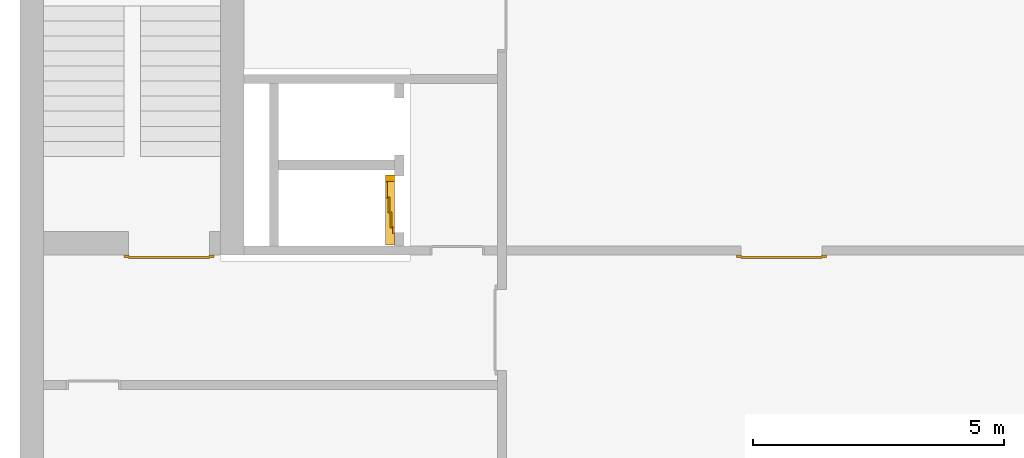
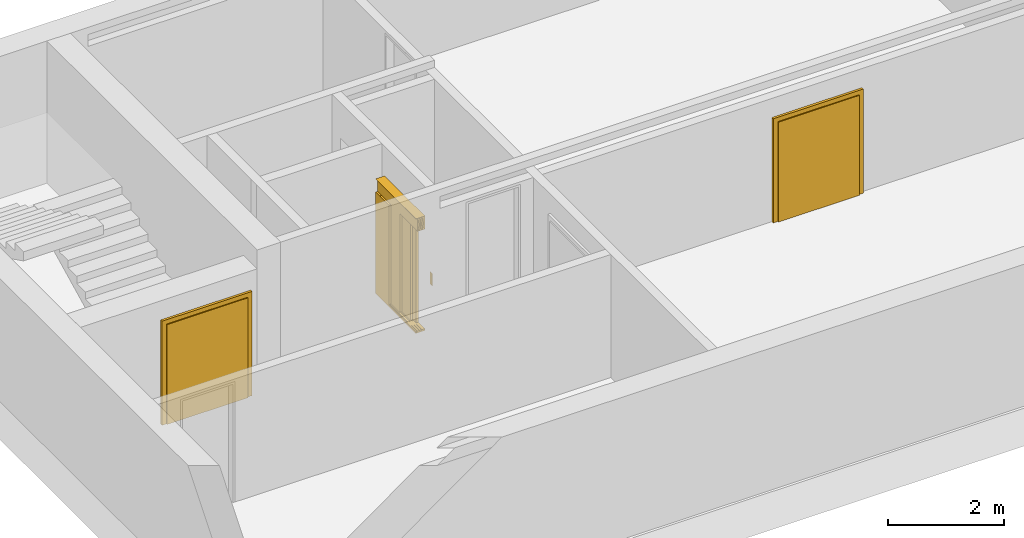
# One storey, part 3 of 3: 3 doors.
"""IFC4 building model written with IfcOpenShell, lengths in metres."""

from ifc_helpers import new_model, entity, si_unit, converted_unit, derived_unit, direction, frame, origin_with_axes, place, context, subcontext, project, spatial, polygons, source, transform, mapped, type_object, element, save


model = new_model("IFC4")

# Units and contexts
model_context = context("Model", 3, precision=1e-05, world=origin_with_axes(), true_north=direction((0.0, 1.0)))
body_context = subcontext(model_context, "Body", "Model", "MODEL_VIEW")
ifc_project = project(units=[si_unit("LENGTHUNIT", "METRE"), si_unit("AREAUNIT", "SQUARE_METRE"), si_unit("VOLUMEUNIT", "CUBIC_METRE"), converted_unit("PLANEANGLEUNIT", "DEGREE", entity("IfcPlaneAngleMeasure", 0.0174532925199433), si_unit("PLANEANGLEUNIT", "RADIAN"), dimensions=[0, 0, 0, 0, 0, 0, 0]), converted_unit("TIMEUNIT", "Year", entity("IfcTimeMeasure", 31557600.0), si_unit("TIMEUNIT", "SECOND"), dimensions=[0, 0, 1, 0, 0, 0, 0]), si_unit("MASSUNIT", "GRAM", prefix="KILO"), si_unit("THERMODYNAMICTEMPERATUREUNIT", "DEGREE_CELSIUS"), si_unit("LUMINOUSINTENSITYUNIT", "LUMEN"), si_unit("ENERGYUNIT", "JOULE", prefix="MEGA"), derived_unit("THERMALCONDUCTANCEUNIT", [(si_unit("POWERUNIT", "WATT"), 1), (si_unit("LENGTHUNIT", "METRE"), -1), (si_unit("THERMODYNAMICTEMPERATUREUNIT", "KELVIN"), -1)]), derived_unit("SPECIFICHEATCAPACITYUNIT", [(si_unit("ENERGYUNIT", "JOULE"), 1), (si_unit("MASSUNIT", "GRAM", prefix="KILO"), -1), (si_unit("THERMODYNAMICTEMPERATUREUNIT", "KELVIN"), -1)]), derived_unit("MASSDENSITYUNIT", [(si_unit("MASSUNIT", "GRAM", prefix="KILO"), 1), (si_unit("VOLUMEUNIT", "CUBIC_METRE"), -1)])], contexts=[model_context])

# Site, building, storey
site_placement = place(None, origin_with_axes())
site = spatial("IfcSite", under=ifc_project, at=site_placement, CompositionType="ELEMENT")
building_placement = place(site_placement, origin_with_axes())
building = spatial("IfcBuilding", under=site, at=building_placement, CompositionType="ELEMENT")
storey_placement = place(building_placement, frame((0.0, 0.0, -3.0), z_axis=(0.0, 0.0, 1.0), x_axis=(1.0, 0.0, 0.0)))
storey = spatial("IfcBuildingStorey", under=building, at=storey_placement, Name="UG", CompositionType="ELEMENT", Elevation=-3.0)

# Doors
door_type_1 = type_object("IfcDoorType", OperationType="DOUBLE_DOOR_SINGLE_SWING", PredefinedType="DOOR")
shared_shape_1 = source(origin_with_axes(), body_context, "Body", "Tessellation", [
    polygons([(-0.9, 0.0, 0.0), (-0.9, 0.0, 2.2), (-0.9, 0.03, 2.2), (-0.9, 0.03, 0.0), (-0.8, 0.0, 0.0), (-0.8, 0.0, 2.1), (-0.1101, 0.0, 2.1), (-0.0001, 0.0, 2.1), (0.8, 0.0, 2.1), (0.8, 0.0, 0.0), (0.9, 0.0, 0.0), (0.9, 0.0, 2.2), (0.9, 0.03, 2.2), (0.9, 0.03, 0.0), (0.8, 0.03, 0.0), (0.8, 0.03, 2.1), (-0.0001, 0.03, 2.1), (-0.1101, 0.03, 2.1), (-0.8, 0.03, 2.1), (-0.8, 0.03, 0.0)], [[[1, 2, 3, 4]], [[1, 5, 6, 7, 8, 9, 10, 11, 12, 2]], [[2, 12, 13, 3]], [[4, 3, 13, 14, 15, 16, 17, 18, 19, 20]], [[5, 1, 4, 20]], [[6, 5, 20, 19]], [[7, 6, 19, 18]], [[8, 7, 18, 17]], [[9, 8, 17, 16]], [[10, 9, 16, 15]], [[11, 10, 15, 14]], [[12, 11, 14, 13]]], closed=True),
    polygons([(-0.9, 0.03, 0.0), (-0.9, 0.03, 2.2), (-0.9, 0.05, 2.2), (-0.9, 0.05, 0.0), (-0.81, 0.03, 0.0), (-0.81, 0.03, 2.11), (-0.1001, 0.03, 2.11), (-0.0101, 0.03, 2.11), (0.81, 0.03, 2.11), (0.81, 0.03, 0.0), (0.9, 0.03, 0.0), (0.9, 0.03, 2.2), (0.9, 0.05, 2.2), (0.9, 0.05, 0.0), (0.81, 0.05, 0.0), (0.81, 0.05, 2.11), (-0.0101, 0.05, 2.11), (-0.1001, 0.05, 2.11), (-0.81, 0.05, 2.11), (-0.81, 0.05, 0.0)], [[[1, 2, 3, 4]], [[1, 5, 6, 7, 8, 9, 10, 11, 12, 2]], [[2, 12, 13, 3]], [[4, 3, 13, 14, 15, 16, 17, 18, 19, 20]], [[5, 1, 4, 20]], [[6, 5, 20, 19]], [[7, 6, 19, 18]], [[8, 7, 18, 17]], [[9, 8, 17, 16]], [[10, 9, 16, 15]], [[11, 10, 15, 14]], [[12, 11, 14, 13]]], closed=True),
    polygons([(-0.81, 0.07, 0.0), (-0.81, 0.07, 2.11), (-0.000499999999999945, 0.07, 2.11), (-0.000499999999999945, 0.07, 0.0), (-0.81, 0.03, 0.0), (-0.81, 0.03, 2.11), (-0.000499999999999945, 0.03, 2.11), (-0.000499999999999945, 0.03, 0.0)], [[[1, 2, 3, 4]], [[1, 5, 6, 2]], [[2, 6, 7, 3]], [[3, 7, 8, 4]], [[4, 8, 5, 1]], [[8, 7, 6, 5]]], closed=True),
    polygons([(0.81, 0.07, 0.0), (0.000499999999999945, 0.07, 0.0), (0.000499999999999945, 0.07, 2.11), (0.81, 0.07, 2.11), (0.81, 0.03, 0.0), (0.000499999999999945, 0.03, 0.0), (0.000499999999999945, 0.03, 2.11), (0.81, 0.03, 2.11)], [[[1, 2, 3, 4]], [[2, 1, 5, 6]], [[3, 2, 6, 7]], [[4, 3, 7, 8]], [[1, 4, 8, 5]], [[6, 5, 8, 7]]], closed=True),
])
door_1_placement = place(storey_placement, frame((39.968657642847, 7.05499994546755, 0.0), z_axis=(0.0, 0.0, 1.0), x_axis=(-1.0, 0.0, 0.0)))
element("IfcDoor", 1, at=door_1_placement, inside=storey, type_object=door_type_1, OverallHeight=2.11, OverallWidth=1.62, PredefinedType="DOOR", context=body_context, shape_type="MappedRepresentation", body=[
    mapped(shared_shape_1, transform((0.799999999999997, 0.0, 0.0))),
])
shared_shape_2 = source(origin_with_axes(), body_context, "Body", "Tessellation", [
    polygons([(-0.9, 0.0, 0.0), (-0.9, 0.0, 2.2), (-0.9, 0.03, 2.2), (-0.9, 0.03, 0.0), (-0.8, 0.0, 0.0), (-0.8, 0.0, 2.1), (-0.1101, 0.0, 2.1), (-0.0001, 0.0, 2.1), (0.8, 0.0, 2.1), (0.8, 0.0, 0.0), (0.9, 0.0, 0.0), (0.9, 0.0, 2.2), (0.9, 0.03, 2.2), (0.9, 0.03, 0.0), (0.8, 0.03, 0.0), (0.8, 0.03, 2.1), (-0.0001, 0.03, 2.1), (-0.1101, 0.03, 2.1), (-0.8, 0.03, 2.1), (-0.8, 0.03, 0.0)], [[[1, 2, 3, 4]], [[1, 5, 6, 7, 8, 9, 10, 11, 12, 2]], [[2, 12, 13, 3]], [[4, 3, 13, 14, 15, 16, 17, 18, 19, 20]], [[5, 1, 4, 20]], [[6, 5, 20, 19]], [[7, 6, 19, 18]], [[8, 7, 18, 17]], [[9, 8, 17, 16]], [[10, 9, 16, 15]], [[11, 10, 15, 14]], [[12, 11, 14, 13]]], closed=True),
    polygons([(-0.9, 0.03, 0.0), (-0.9, 0.03, 2.2), (-0.9, 0.05, 2.2), (-0.9, 0.05, 0.0), (-0.81, 0.03, 0.0), (-0.81, 0.03, 2.11), (-0.1001, 0.03, 2.11), (-0.0101, 0.03, 2.11), (0.81, 0.03, 2.11), (0.81, 0.03, 0.0), (0.9, 0.03, 0.0), (0.9, 0.03, 2.2), (0.9, 0.05, 2.2), (0.9, 0.05, 0.0), (0.81, 0.05, 0.0), (0.81, 0.05, 2.11), (-0.0101, 0.05, 2.11), (-0.1001, 0.05, 2.11), (-0.81, 0.05, 2.11), (-0.81, 0.05, 0.0)], [[[1, 2, 3, 4]], [[1, 5, 6, 7, 8, 9, 10, 11, 12, 2]], [[2, 12, 13, 3]], [[4, 3, 13, 14, 15, 16, 17, 18, 19, 20]], [[5, 1, 4, 20]], [[6, 5, 20, 19]], [[7, 6, 19, 18]], [[8, 7, 18, 17]], [[9, 8, 17, 16]], [[10, 9, 16, 15]], [[11, 10, 15, 14]], [[12, 11, 14, 13]]], closed=True),
    polygons([(-0.81, 0.07, 0.0), (-0.81, 0.07, 2.11), (-0.000499999999999945, 0.07, 2.11), (-0.000499999999999945, 0.07, 0.0), (-0.81, 0.03, 0.0), (-0.81, 0.03, 2.11), (-0.000499999999999945, 0.03, 2.11), (-0.000499999999999945, 0.03, 0.0)], [[[1, 2, 3, 4]], [[1, 5, 6, 2]], [[2, 6, 7, 3]], [[3, 7, 8, 4]], [[4, 8, 5, 1]], [[8, 7, 6, 5]]], closed=True),
    polygons([(0.81, 0.07, 0.0), (0.000499999999999945, 0.07, 0.0), (0.000499999999999945, 0.07, 2.11), (0.81, 0.07, 2.11), (0.81, 0.03, 0.0), (0.000499999999999945, 0.03, 0.0), (0.000499999999999945, 0.03, 2.11), (0.81, 0.03, 2.11)], [[[1, 2, 3, 4]], [[2, 1, 5, 6]], [[3, 2, 6, 7]], [[4, 3, 7, 8]], [[1, 4, 8, 5]], [[6, 5, 8, 7]]], closed=True),
])
door_2_placement = place(storey_placement, frame((27.758, 7.05499994546755, 0.0), z_axis=(0.0, 0.0, 1.0), x_axis=(-1.0, 0.0, 0.0)))
element("IfcDoor", 2, at=door_2_placement, inside=storey, type_object=door_type_1, OverallHeight=2.11, OverallWidth=1.62, PredefinedType="DOOR", context=body_context, shape_type="MappedRepresentation", body=[
    mapped(shared_shape_2, transform((0.800000000000001, 0.0, 0.0))),
])
door_type_2 = type_object("IfcDoorType", Name="27", OperationType="DOUBLE_DOOR_SLIDING", PredefinedType="DOOR")
shared_shape_3 = source(origin_with_axes(), body_context, "Body", "Tessellation", [
    polygons([(-0.808333333333334, 0.135, 2.1), (-0.808333333333334, 0.135, 2.138), (0.585, 0.135, 2.138), (0.585, 0.135, 2.1), (-0.808333333333334, 0.0, 2.1), (-0.808333333333334, 0.0, 2.38), (-0.808333333333334, 0.18, 2.38), (-0.808333333333334, 0.18, 2.377), (-0.808333333333334, 0.003, 2.377), (-0.808333333333334, 0.003, 2.103), (-0.808333333333334, 0.132, 2.103), (-0.808333333333334, 0.132, 2.138), (0.585, 0.132, 2.138), (0.585, 0.132, 2.103), (0.585, 0.00299999999999992, 2.103), (0.585, 0.00299999999999992, 2.377), (0.585, 0.18, 2.377), (0.585, 0.18, 2.38), (0.585, 0.0, 2.38), (0.585, 0.0, 2.1)], [[[1, 2, 3, 4]], [[1, 5, 6, 7, 8, 9, 10, 11, 12, 2]], [[2, 12, 13, 3]], [[4, 3, 13, 14, 15, 16, 17, 18, 19, 20]], [[5, 1, 4, 20]], [[6, 5, 20, 19]], [[7, 6, 19, 18]], [[8, 7, 18, 17]], [[9, 8, 17, 16]], [[10, 9, 16, 15]], [[11, 10, 15, 14]], [[12, 11, 14, 13]]], closed=True),
    polygons([(-0.808333333333334, 0.05, 2.103), (-0.808333333333334, 0.055, 2.103), (0.585, 0.0549999999999999, 2.103), (0.585, 0.0499999999999999, 2.103), (-0.808333333333334, 0.05, 2.34), (-0.808333333333334, 0.055, 2.34), (0.585, 0.0549999999999999, 2.34), (0.585, 0.0499999999999999, 2.34)], [[[1, 2, 3, 4]], [[1, 5, 6, 2]], [[2, 6, 7, 3]], [[4, 3, 7, 8]], [[5, 1, 4, 8]], [[6, 5, 8, 7]]], closed=True),
    polygons([(-0.808333333333334, 0.05, 2.33), (-0.808333333333334, 0.04, 2.33), (0.585, 0.0399999999999999, 2.33), (0.585, 0.0499999999999999, 2.33), (-0.808333333333334, 0.05, 2.27), (-0.808333333333334, 0.04, 2.27), (0.585, 0.0399999999999999, 2.27), (0.585, 0.0499999999999999, 2.27)], [[[1, 2, 3, 4]], [[1, 5, 6, 2]], [[2, 6, 7, 3]], [[4, 3, 7, 8]], [[5, 1, 4, 8]], [[6, 5, 8, 7]]], closed=True),
    polygons([(-0.808333333333334, 0.05, 2.2), (-0.808333333333334, 0.04, 2.2), (0.585, 0.0399999999999999, 2.2), (0.585, 0.0499999999999999, 2.2), (-0.808333333333334, 0.05, 2.16), (-0.808333333333334, 0.04, 2.16), (0.585, 0.0399999999999999, 2.16), (0.585, 0.0499999999999999, 2.16)], [[[1, 2, 3, 4]], [[1, 5, 6, 2]], [[2, 6, 7, 3]], [[4, 3, 7, 8]], [[5, 1, 4, 8]], [[6, 5, 8, 7]]], closed=True),
    polygons([(-0.808333333333334, 0.05, 2.27), (-0.808333333333334, 0.03, 2.27), (0.585, 0.0299999999999999, 2.27), (0.585, 0.0499999999999999, 2.27), (-0.808333333333334, 0.05, 2.2), (-0.808333333333334, 0.03, 2.2), (0.585, 0.0299999999999999, 2.2), (0.585, 0.0499999999999999, 2.2)], [[[1, 2, 3, 4]], [[1, 5, 6, 2]], [[2, 6, 7, 3]], [[4, 3, 7, 8]], [[5, 1, 4, 8]], [[6, 5, 8, 7]]], closed=True),
    polygons([(-0.808333333333334, 0.095, 2.103), (-0.808333333333334, 0.1, 2.103), (0.585, 0.0999999999999999, 2.103), (0.585, 0.0949999999999999, 2.103), (-0.808333333333334, 0.095, 2.34), (-0.808333333333334, 0.1, 2.34), (0.585, 0.0999999999999999, 2.34), (0.585, 0.0949999999999999, 2.34)], [[[1, 2, 3, 4]], [[1, 5, 6, 2]], [[2, 6, 7, 3]], [[4, 3, 7, 8]], [[5, 1, 4, 8]], [[6, 5, 8, 7]]], closed=True),
    polygons([(-0.808333333333334, 0.095, 2.33), (-0.808333333333334, 0.085, 2.33), (0.585, 0.0849999999999999, 2.33), (0.585, 0.0949999999999999, 2.33), (-0.808333333333334, 0.095, 2.27), (-0.808333333333334, 0.085, 2.27), (0.585, 0.0849999999999999, 2.27), (0.585, 0.0949999999999999, 2.27)], [[[1, 2, 3, 4]], [[1, 5, 6, 2]], [[2, 6, 7, 3]], [[4, 3, 7, 8]], [[5, 1, 4, 8]], [[6, 5, 8, 7]]], closed=True),
    polygons([(-0.808333333333334, 0.095, 2.2), (-0.808333333333334, 0.085, 2.2), (0.585, 0.0849999999999999, 2.2), (0.585, 0.0949999999999999, 2.2), (-0.808333333333334, 0.095, 2.16), (-0.808333333333334, 0.085, 2.16), (0.585, 0.0849999999999999, 2.16), (0.585, 0.0949999999999999, 2.16)], [[[1, 2, 3, 4]], [[1, 5, 6, 2]], [[2, 6, 7, 3]], [[4, 3, 7, 8]], [[5, 1, 4, 8]], [[6, 5, 8, 7]]], closed=True),
    polygons([(-0.808333333333334, 0.095, 2.27), (-0.808333333333334, 0.075, 2.27), (0.585, 0.0749999999999999, 2.27), (0.585, 0.0949999999999999, 2.27), (-0.808333333333334, 0.095, 2.2), (-0.808333333333334, 0.075, 2.2), (0.585, 0.0749999999999999, 2.2), (0.585, 0.0949999999999999, 2.2)], [[[1, 2, 3, 4]], [[1, 5, 6, 2]], [[2, 6, 7, 3]], [[4, 3, 7, 8]], [[5, 1, 4, 8]], [[6, 5, 8, 7]]], closed=True),
    polygons([(-0.808333333333334, 0.14, 2.103), (-0.808333333333334, 0.145, 2.103), (0.585, 0.145, 2.103), (0.585, 0.14, 2.103), (-0.808333333333334, 0.14, 2.34), (-0.808333333333334, 0.145, 2.34), (0.585, 0.145, 2.34), (0.585, 0.14, 2.34)], [[[1, 2, 3, 4]], [[1, 5, 6, 2]], [[2, 6, 7, 3]], [[4, 3, 7, 8]], [[5, 1, 4, 8]], [[6, 5, 8, 7]]], closed=True),
    polygons([(-0.808333333333334, 0.14, 2.33), (-0.808333333333334, 0.13, 2.33), (0.585, 0.13, 2.33), (0.585, 0.14, 2.33), (-0.808333333333334, 0.14, 2.27), (-0.808333333333334, 0.13, 2.27), (0.585, 0.13, 2.27), (0.585, 0.14, 2.27)], [[[1, 2, 3, 4]], [[1, 5, 6, 2]], [[2, 6, 7, 3]], [[4, 3, 7, 8]], [[5, 1, 4, 8]], [[6, 5, 8, 7]]], closed=True),
    polygons([(-0.808333333333334, 0.14, 2.2), (-0.808333333333334, 0.13, 2.2), (0.585, 0.13, 2.2), (0.585, 0.14, 2.2), (-0.808333333333334, 0.14, 2.16), (-0.808333333333334, 0.13, 2.16), (0.585, 0.13, 2.16), (0.585, 0.14, 2.16)], [[[1, 2, 3, 4]], [[1, 5, 6, 2]], [[2, 6, 7, 3]], [[4, 3, 7, 8]], [[5, 1, 4, 8]], [[6, 5, 8, 7]]], closed=True),
    polygons([(-0.808333333333334, 0.14, 2.27), (-0.808333333333334, 0.12, 2.27), (0.585, 0.12, 2.27), (0.585, 0.14, 2.27), (-0.808333333333334, 0.14, 2.2), (-0.808333333333334, 0.12, 2.2), (0.585, 0.12, 2.2), (0.585, 0.14, 2.2)], [[[1, 2, 3, 4]], [[1, 5, 6, 2]], [[2, 6, 7, 3]], [[4, 3, 7, 8]], [[5, 1, 4, 8]], [[6, 5, 8, 7]]], closed=True),
    polygons([(-0.808333333333334, 0.0, 0.0), (-0.808333333333334, 0.0, -0.04), (0.585, 0.0, -0.04), (0.585, 0.0, 0.0), (-0.808333333333334, 0.065, 0.0), (-0.808333333333334, 0.065, -0.01), (-0.808333333333334, 0.075, -0.01), (-0.808333333333334, 0.075, 0.0), (-0.808333333333334, 0.11, 0.0), (-0.808333333333334, 0.11, -0.01), (-0.808333333333334, 0.12, -0.01), (-0.808333333333334, 0.12, 0.0), (-0.808333333333334, 0.155, 0.0), (-0.808333333333334, 0.155, -0.01), (-0.808333333333334, 0.165, -0.01), (-0.808333333333334, 0.165, 0.0), (-0.808333333333334, 0.18, 0.0), (-0.808333333333334, 0.18, -0.04), (0.585, 0.18, -0.04), (0.585, 0.18, 0.0), (0.585, 0.165, 0.0), (0.585, 0.165, -0.01), (0.585, 0.155, -0.01), (0.585, 0.155, 0.0), (0.585, 0.12, 0.0), (0.585, 0.12, -0.01), (0.585, 0.11, -0.01), (0.585, 0.11, 0.0), (0.585, 0.0749999999999999, 0.0), (0.585, 0.0749999999999999, -0.01), (0.585, 0.0649999999999999, -0.01), (0.585, 0.0649999999999999, 0.0)], [[[1, 2, 3, 4]], [[1, 5, 6, 7, 8, 9, 10, 11, 12, 13, 14, 15, 16, 17, 18, 2]], [[2, 18, 19, 3]], [[4, 3, 19, 20, 21, 22, 23, 24, 25, 26, 27, 28, 29, 30, 31, 32]], [[5, 1, 4, 32]], [[6, 5, 32, 31]], [[7, 6, 31, 30]], [[8, 7, 30, 29]], [[9, 8, 29, 28]], [[10, 9, 28, 27]], [[11, 10, 27, 26]], [[12, 11, 26, 25]], [[13, 12, 25, 24]], [[14, 13, 24, 23]], [[15, 14, 23, 22]], [[16, 15, 22, 21]], [[17, 16, 21, 20]], [[18, 17, 20, 19]]], closed=True),
    polygons([(-0.45, 0.0, 0.0), (-0.45, 0.045, 0.0), (-0.45, 0.0449999999999999, 2.1), (-0.45, 0.0, 2.1), (-0.585, 0.0, 0.0), (-0.585, 0.045, 0.0), (-0.585, 0.0449999999999999, 2.1), (-0.585, 0.0, 2.1)], [[[1, 2, 3, 4]], [[1, 5, 6, 2]], [[2, 6, 7, 3]], [[4, 3, 7, 8]], [[5, 1, 4, 8]], [[6, 5, 8, 7]]], closed=True),
    polygons([(0.585, 0.0, 0.0), (0.585, 0.18, 0.0), (0.585, 0.18, 2.1), (0.585, 0.0, 2.1), (0.45, 0.0, 0.0), (0.45, 0.18, 0.0), (0.45, 0.18, 2.1), (0.45, 0.0, 2.1)], [[[1, 2, 3, 4]], [[1, 5, 6, 2]], [[2, 6, 7, 3]], [[4, 3, 7, 8]], [[5, 1, 4, 8]], [[6, 5, 8, 7]]], closed=True),
    polygons([(-0.745, -0.18, 0.8), (-0.665, -0.18, 0.8), (-0.665, -0.183, 0.8), (-0.745, -0.183, 0.8), (-0.745, -0.18, 1.06), (-0.665, -0.18, 1.06), (-0.735, -0.18, 1.03), (-0.735, -0.18, 0.94), (-0.675, -0.18, 0.94), (-0.675, -0.18, 1.03), (-0.715, -0.18, 0.84), (-0.695, -0.18, 0.84), (-0.695, -0.18, 0.86), (-0.715, -0.18, 0.86), (-0.715, -0.18, 0.88), (-0.695, -0.18, 0.88), (-0.695, -0.18, 0.9), (-0.715, -0.18, 0.9), (-0.665, -0.183, 1.06), (-0.745, -0.183, 1.06), (-0.735, -0.183, 1.03), (-0.675, -0.183, 1.03), (-0.675, -0.183, 0.94), (-0.735, -0.183, 0.94), (-0.715, -0.183, 0.84), (-0.715, -0.183, 0.86), (-0.695, -0.183, 0.86), (-0.695, -0.183, 0.84), (-0.715, -0.183, 0.88), (-0.715, -0.183, 0.9), (-0.695, -0.183, 0.9), (-0.695, -0.183, 0.88)], [[[1, 2, 3, 4]], [[1, 5, 6, 2], [7, 8, 9, 10], [11, 12, 13, 14], [15, 16, 17, 18]], [[2, 6, 19, 3]], [[4, 3, 19, 20], [21, 22, 23, 24], [25, 26, 27, 28], [29, 30, 31, 32]], [[5, 1, 4, 20]], [[6, 5, 20, 19]], [[8, 7, 21, 24]], [[9, 8, 24, 23]], [[10, 9, 23, 22]], [[7, 10, 22, 21]], [[12, 11, 25, 28]], [[13, 12, 28, 27]], [[14, 13, 27, 26]], [[11, 14, 26, 25]], [[16, 15, 29, 32]], [[17, 16, 32, 31]], [[18, 17, 31, 30]], [[15, 18, 30, 29]]], closed=True),
    polygons([(-0.735, -0.18, 0.94), (-0.675, -0.18, 0.94), (-0.675, -0.1825, 0.94), (-0.735, -0.1825, 0.94), (-0.735, -0.18, 1.03), (-0.675, -0.18, 1.03), (-0.675, -0.1825, 1.03), (-0.735, -0.1825, 1.03)], [[[1, 2, 3, 4]], [[1, 5, 6, 2]], [[2, 6, 7, 3]], [[4, 3, 7, 8]], [[5, 1, 4, 8]], [[6, 5, 8, 7]]], closed=True),
    polygons([(-0.721, -0.183, 1.005), (-0.715, -0.183, 1.021), (-0.709, -0.183, 1.005)], [[[1, 2, 3]]], closed=False),
    polygons([(-0.695, -0.183, 1.005), (-0.701, -0.183, 1.021), (-0.689, -0.183, 1.021)], [[[1, 2, 3]]], closed=False),
    polygons([(-0.707727272727273, -0.1835, 0.982), (-0.707727272727273, -0.1835, 0.971636363636364), (-0.709090909090909, -0.1835, 0.970272727272727), (-0.710454545454546, -0.1835, 0.971636363636364), (-0.710454545454546, -0.1835, 0.982), (-0.709090909090909, -0.1835, 0.983363636363636)], [[[1, 2, 3, 4, 5, 6]]], closed=False),
    polygons([(-0.707727272727273, -0.1835, 0.968363636363636), (-0.707727272727273, -0.1835, 0.958), (-0.709090909090909, -0.1835, 0.956636363636364), (-0.710454545454546, -0.1835, 0.958), (-0.710454545454546, -0.1835, 0.968363636363636), (-0.709090909090909, -0.1835, 0.969727272727273)], [[[1, 2, 3, 4, 5, 6]]], closed=False),
    polygons([(-0.688909090909091, -0.1835, 0.982272727272727), (-0.699272727272727, -0.1835, 0.982272727272727), (-0.700636363636364, -0.1835, 0.983636363636364), (-0.699272727272727, -0.1835, 0.985), (-0.688909090909091, -0.1835, 0.985), (-0.687545454545455, -0.1835, 0.983636363636364)], [[[1, 2, 3, 4, 5, 6]]], closed=False),
    polygons([(-0.685909090909091, -0.1835, 0.982), (-0.685909090909091, -0.1835, 0.971636363636364), (-0.687272727272727, -0.1835, 0.970272727272727), (-0.688636363636364, -0.1835, 0.971636363636364), (-0.688636363636364, -0.1835, 0.982), (-0.687272727272727, -0.1835, 0.983363636363636)], [[[1, 2, 3, 4, 5, 6]]], closed=False),
    polygons([(-0.688909090909091, -0.1835, 0.968636363636364), (-0.699272727272727, -0.1835, 0.968636363636364), (-0.700636363636364, -0.1835, 0.97), (-0.699272727272727, -0.1835, 0.971363636363636), (-0.688909090909091, -0.1835, 0.971363636363636), (-0.687545454545455, -0.1835, 0.97)], [[[1, 2, 3, 4, 5, 6]]], closed=False),
    polygons([(-0.699545454545455, -0.1835, 0.968363636363636), (-0.699545454545455, -0.1835, 0.958), (-0.700909090909091, -0.1835, 0.956636363636364), (-0.702272727272727, -0.1835, 0.958), (-0.702272727272727, -0.1835, 0.968363636363636), (-0.700909090909091, -0.1835, 0.969727272727273)], [[[1, 2, 3, 4, 5, 6]]], closed=False),
    polygons([(-0.688909090909091, -0.1835, 0.955), (-0.699272727272727, -0.1835, 0.955), (-0.700636363636364, -0.1835, 0.956363636363636), (-0.699272727272727, -0.1835, 0.957727272727273), (-0.688909090909091, -0.1835, 0.957727272727273), (-0.687545454545455, -0.1835, 0.956363636363636)], [[[1, 2, 3, 4, 5, 6]]], closed=False),
    polygons([(-0.695, -0.18, 0.84), (-0.715, -0.18, 0.84), (-0.715, -0.18, 0.86), (-0.695, -0.18, 0.86), (-0.694999999905229, -0.1815, 0.839999999610484), (-0.715000000389516, -0.1815, 0.839999999610484), (-0.715000000389516, -0.1815, 0.860000000094772), (-0.694999999905229, -0.1815, 0.860000000094772), (-0.696400000320971, -0.182900000415742, 0.841400000026226), (-0.713599999973774, -0.182900000415742, 0.841400000026226), (-0.713599999973774, -0.182900000415742, 0.858599999679029), (-0.696400000320971, -0.182900000415742, 0.858599999679029)], [[[1, 2, 3, 4]], [[2, 1, 5, 6]], [[3, 2, 6, 7]], [[4, 3, 7, 8]], [[1, 4, 8, 5]], [[6, 5, 9, 10]], [[7, 6, 10, 11]], [[8, 7, 11, 12]], [[5, 8, 12, 9]], [[11, 10, 9, 12]]], closed=True),
    polygons([(-0.7, -0.183, 0.855), (-0.705, -0.183, 0.844), (-0.71, -0.183, 0.855)], [[[1, 2, 3]]], closed=False),
    polygons([(-0.695, -0.18, 0.88), (-0.715, -0.18, 0.88), (-0.715, -0.18, 0.9), (-0.695, -0.18, 0.9), (-0.694999999905229, -0.1815, 0.879999999610484), (-0.715000000389516, -0.1815, 0.879999999610484), (-0.715000000389516, -0.1815, 0.900000000094772), (-0.694999999905229, -0.1815, 0.900000000094772), (-0.696400000320971, -0.182900000415742, 0.881400000026226), (-0.713599999973774, -0.182900000415742, 0.881400000026226), (-0.713599999973774, -0.182900000415742, 0.898599999679029), (-0.696400000320971, -0.182900000415742, 0.898599999679029)], [[[1, 2, 3, 4]], [[2, 1, 5, 6]], [[3, 2, 6, 7]], [[4, 3, 7, 8]], [[1, 4, 8, 5]], [[6, 5, 9, 10]], [[7, 6, 10, 11]], [[8, 7, 11, 12]], [[5, 8, 12, 9]], [[11, 10, 9, 12]]], closed=True),
    polygons([(-0.7, -0.183, 0.885), (-0.71, -0.183, 0.885), (-0.705, -0.183, 0.896)], [[[1, 2, 3]]], closed=False),
    polygons([(0.126666666666667, 0.14, 0.003), (0.126666666666667, 0.18, 0.003), (0.445, 0.18, 0.003), (0.445, 0.14, 0.003), (0.126666666666667, 0.14, 2.1), (0.126666666666667, 0.18, 2.1), (0.445, 0.18, 2.1), (0.445, 0.14, 2.1)], [[[1, 2, 3, 4]], [[5, 6, 2, 1]], [[2, 6, 7, 3]], [[4, 3, 7, 8]], [[1, 4, 8, 5]], [[8, 7, 6, 5]]], closed=True),
    polygons([(-0.171666666666667, 0.095, 0.003), (-0.171666666666667, 0.135, 0.003), (0.146666666666667, 0.135, 0.003), (0.146666666666667, 0.095, 0.003), (-0.171666666666667, 0.095, 2.1), (-0.171666666666667, 0.135, 2.1), (0.146666666666667, 0.135, 2.1), (0.146666666666667, 0.095, 2.1)], [[[1, 2, 3, 4]], [[5, 6, 2, 1]], [[2, 6, 7, 3]], [[4, 3, 7, 8]], [[1, 4, 8, 5]], [[8, 7, 6, 5]]], closed=True),
    polygons([(-0.47, 0.05, 0.003), (-0.47, 0.09, 0.003), (-0.151666666666667, 0.09, 0.003), (-0.151666666666667, 0.05, 0.003), (-0.47, 0.05, 2.1), (-0.47, 0.09, 2.1), (-0.151666666666667, 0.09, 2.1), (-0.151666666666667, 0.05, 2.1)], [[[1, 2, 3, 4]], [[5, 6, 2, 1]], [[2, 6, 7, 3]], [[4, 3, 7, 8]], [[1, 4, 8, 5]], [[8, 7, 6, 5]]], closed=True),
])
door_3_placement = place(storey_placement, frame((31.638, 7.61999994546756, 0.0), z_axis=(0.0, 0.0, 1.0), x_axis=(0.0, 1.0, 0.0)))
element("IfcDoor", 3, at=door_3_placement, inside=storey, type_object=door_type_2, OverallHeight=2.25, OverallWidth=1.13, PredefinedType="DOOR", context=body_context, shape_type="MappedRepresentation", body=[
    mapped(shared_shape_3, transform((0.450000000000001, 0.18, 0.0))),
])

save(model, "model.ifc")
